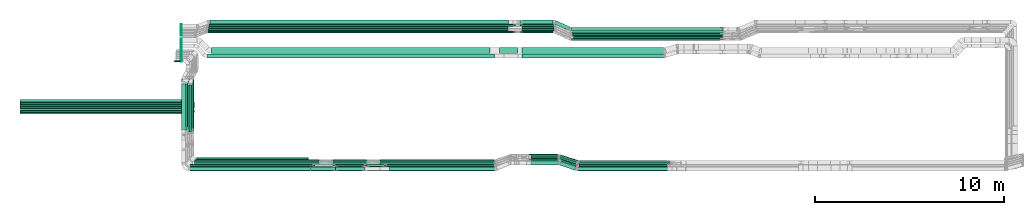
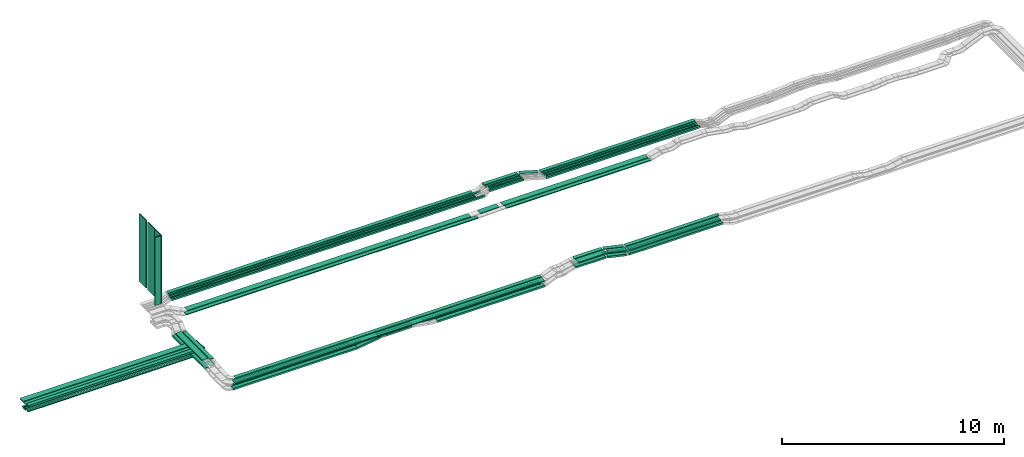
# One storey, part 1 of 28: 74 flow segments.
"""IFC2X3 building model written with IfcOpenShell, lengths in millimetres."""

from ifc_helpers import new_model, entity, si_unit, converted_unit, derived_unit, direction, frame, origin, origin_2d_with_axis, place, context, subcontext, project, spatial, rectangle, extrude, type_object, element, save


model = new_model("IFC2X3")

# Units and contexts
model_context = context("Model", 3, precision=0.01, world=origin(), true_north=direction((6.12303176911189e-17, 1.0)))
body_context = subcontext(model_context, "Body", "Model", "MODEL_VIEW")
ifc_project = project(units=[si_unit("LENGTHUNIT", "METRE", prefix="MILLI"), si_unit("AREAUNIT", "SQUARE_METRE"), si_unit("VOLUMEUNIT", "CUBIC_METRE"), converted_unit("PLANEANGLEUNIT", "DEGREE", entity("IfcRatioMeasure", 0.0174532925199433), si_unit("PLANEANGLEUNIT", "RADIAN"), dimensions=[0, 0, 0, 0, 0, 0, 0]), si_unit("MASSUNIT", "GRAM", prefix="KILO"), derived_unit("MASSDENSITYUNIT", [(si_unit("MASSUNIT", "GRAM", prefix="KILO"), 1), (si_unit("LENGTHUNIT", "METRE"), -3)]), derived_unit("MOMENTOFINERTIAUNIT", [(si_unit("LENGTHUNIT", "METRE"), 4)]), si_unit("TIMEUNIT", "SECOND"), si_unit("FREQUENCYUNIT", "HERTZ"), si_unit("THERMODYNAMICTEMPERATUREUNIT", "DEGREE_CELSIUS"), derived_unit("THERMALTRANSMITTANCEUNIT", [(si_unit("MASSUNIT", "GRAM", prefix="KILO"), 1), (si_unit("THERMODYNAMICTEMPERATUREUNIT", "KELVIN"), -1), (si_unit("TIMEUNIT", "SECOND"), -3)]), derived_unit("VOLUMETRICFLOWRATEUNIT", [(si_unit("LENGTHUNIT", "METRE"), 3), (si_unit("TIMEUNIT", "SECOND"), -1)]), derived_unit("MASSFLOWRATEUNIT", [(si_unit("MASSUNIT", "GRAM", prefix="KILO"), 1), (si_unit("TIMEUNIT", "SECOND"), -1)]), derived_unit("ROTATIONALFREQUENCYUNIT", [(si_unit("TIMEUNIT", "SECOND"), -1)]), si_unit("ELECTRICCURRENTUNIT", "AMPERE"), si_unit("ELECTRICVOLTAGEUNIT", "VOLT"), si_unit("POWERUNIT", "WATT"), si_unit("FORCEUNIT", "NEWTON", prefix="KILO"), si_unit("ILLUMINANCEUNIT", "LUX"), si_unit("LUMINOUSFLUXUNIT", "LUMEN"), si_unit("LUMINOUSINTENSITYUNIT", "CANDELA"), derived_unit("USERDEFINED", [(si_unit("MASSUNIT", "GRAM", prefix="KILO"), -1), (si_unit("LENGTHUNIT", "METRE"), -2), (si_unit("TIMEUNIT", "SECOND"), 3), (si_unit("LUMINOUSFLUXUNIT", "LUMEN"), 1)]), derived_unit("LINEARVELOCITYUNIT", [(si_unit("LENGTHUNIT", "METRE"), 1), (si_unit("TIMEUNIT", "SECOND"), -1)]), si_unit("PRESSUREUNIT", "PASCAL"), derived_unit("USERDEFINED", [(si_unit("LENGTHUNIT", "METRE"), -2), (si_unit("MASSUNIT", "GRAM", prefix="KILO"), 1), (si_unit("TIMEUNIT", "SECOND"), -2)]), derived_unit("LINEARFORCEUNIT", [(si_unit("MASSUNIT", "GRAM", prefix="KILO"), 1), (si_unit("LENGTHUNIT", "METRE"), 1), (si_unit("TIMEUNIT", "SECOND"), -2), (si_unit("LENGTHUNIT", "METRE"), -1)]), derived_unit("PLANARFORCEUNIT", [(si_unit("MASSUNIT", "GRAM", prefix="KILO"), 1), (si_unit("LENGTHUNIT", "METRE"), 1), (si_unit("TIMEUNIT", "SECOND"), -2), (si_unit("LENGTHUNIT", "METRE"), -2)])], contexts=[model_context])

# Site, building, storey
site_placement = place(None, origin())
site = spatial("IfcSite", under=ifc_project, at=site_placement, CompositionType="ELEMENT")
building_placement = place(site_placement, origin())
building = spatial("IfcBuilding", under=site, at=building_placement, CompositionType="ELEMENT")
storey_placement = place(building_placement, frame((0.0, 0.0, 15900.0)))
storey = spatial("IfcBuildingStorey", under=building, at=storey_placement, CompositionType="ELEMENT", Elevation=15900.0)

# Flow segments
cable_carrier_segment_type_1 = type_object("IfcCableCarrierSegmentType", PredefinedType="CABLETRAYSEGMENT")
flow_segment_1_placement = place(storey_placement, frame((17073.5, 10315.08, 2607.26)))
element("IfcFlowSegment", 1, at=flow_segment_1_placement, inside=storey, type_object=cable_carrier_segment_type_1, context=body_context, shape_type="SweptSolid", body=[
    extrude(rectangle(XDim=2780.65043288834, YDim=99.9999999999989, at=origin_2d_with_axis()), frame((50.0, 1390.33, 0.0), z_axis=(0.0, 0.0, 1.0), x_axis=(0.0, -1.0, 0.0)), (0.0, 0.0, 1.0), 99.9999999999989),
])
flow_segment_2_placement = place(storey_placement, frame((16853.5, 10214.44, 2607.26)))
element("IfcFlowSegment", 2, at=flow_segment_2_placement, inside=storey, type_object=cable_carrier_segment_type_1, context=body_context, shape_type="SweptSolid", body=[
    extrude(rectangle(XDim=2881.28895515389, YDim=99.9999999999989, at=origin_2d_with_axis()), frame((50.0, 1440.64, 0.0), z_axis=(0.0, 0.0, 1.0), x_axis=(0.0, -1.0, 0.0)), (0.0, 0.0, 1.0), 49.9999999999995),
])
flow_segment_3_placement = place(storey_placement, frame((8000.0, 11314.49, 2532.26)))
element("IfcFlowSegment", 3, at=flow_segment_3_placement, inside=storey, type_object=cable_carrier_segment_type_1, context=body_context, shape_type="SweptSolid", body=[
    extrude(rectangle(XDim=9200.0, YDim=99.9999999999989, at=origin_2d_with_axis()), frame((4600.0, 50.0, 0.0)), (0.0, 0.0, 1.0), 50.0000000000016),
])
flow_segment_4_placement = place(storey_placement, frame((7981.52, 11524.49, 2507.26)))
element("IfcFlowSegment", 4, at=flow_segment_4_placement, inside=storey, type_object=cable_carrier_segment_type_1, context=body_context, shape_type="SweptSolid", body=[
    extrude(rectangle(XDim=9218.48463988693, YDim=99.9999999999989, at=origin_2d_with_axis()), frame((4609.24, 50.0, 0.0)), (0.0, 0.0, 1.0), 99.9999999999989),
])
flow_segment_5_placement = place(storey_placement, frame((7981.52, 11638.05, 2507.26)))
element("IfcFlowSegment", 5, at=flow_segment_5_placement, inside=storey, type_object=cable_carrier_segment_type_1, context=body_context, shape_type="SweptSolid", body=[
    extrude(rectangle(XDim=9218.48463988694, YDim=99.9999999999989, at=origin_2d_with_axis()), frame((4609.24, 50.0, 0.0)), (0.0, 0.0, 1.0), 50.0000000000016),
])
flow_segment_6_placement = place(storey_placement, frame((8000.0, 11748.05, 2507.26)))
element("IfcFlowSegment", 6, at=flow_segment_6_placement, inside=storey, type_object=cable_carrier_segment_type_1, context=body_context, shape_type="SweptSolid", body=[
    extrude(rectangle(XDim=9200.0, YDim=99.9999999999989, at=origin_2d_with_axis()), frame((4600.0, 50.0, 0.0)), (0.0, 0.0, 1.0), 50.0000000000016),
])
flow_segment_7_placement = place(storey_placement, frame((7970.7, 11214.35, 2865.0)))
element("IfcFlowSegment", 7, at=flow_segment_7_placement, inside=storey, type_object=cable_carrier_segment_type_1, context=body_context, shape_type="SweptSolid", body=[
    extrude(rectangle(XDim=9180.0, YDim=200.000000000002, at=origin_2d_with_axis()), frame((4590.0, 100.0, 0.0)), (0.0, 0.0, 1.0), 100.000000000001),
])
flow_segment_8_placement = place(storey_placement, frame((7970.7, 11450.62, 2865.0)))
element("IfcFlowSegment", 8, at=flow_segment_8_placement, inside=storey, type_object=cable_carrier_segment_type_1, context=body_context, shape_type="SweptSolid", body=[
    extrude(rectangle(XDim=9180.0, YDim=199.999999999998, at=origin_2d_with_axis()), frame((4590.0, 100.0, 0.0)), (0.0, 0.0, 1.0), 50.0000000000016),
])
flow_segment_9_placement = place(storey_placement, frame((7970.7, 11685.62, 2865.0)))
element("IfcFlowSegment", 9, at=flow_segment_9_placement, inside=storey, type_object=cable_carrier_segment_type_1, context=body_context, shape_type="SweptSolid", body=[
    extrude(rectangle(XDim=9180.0, YDim=300.000000000001, at=origin_2d_with_axis()), frame((4590.0, 150.0, 0.0)), (0.0, 0.0, 1.0), 50.0000000000016),
])
flow_segment_10_placement = place(storey_placement, frame((24529.62, 8454.97, 2685.0)))
element("IfcFlowSegment", 10, at=flow_segment_10_placement, inside=storey, type_object=cable_carrier_segment_type_1, context=body_context, shape_type="SweptSolid", body=[
    extrude(rectangle(XDim=1786.26303875484, YDim=99.9999999999989, at=origin_2d_with_axis()), frame((893.13, 50.0, 0.0), z_axis=(0.0, 0.0, 1.0), x_axis=(-1.0, 0.0, 0.0)), (0.0, 0.0, 1.0), 99.9999999999989),
])
flow_segment_11_placement = place(storey_placement, frame((24526.24, 8695.5, 2685.0)))
element("IfcFlowSegment", 11, at=flow_segment_11_placement, inside=storey, type_object=cable_carrier_segment_type_1, context=body_context, shape_type="SweptSolid", body=[
    extrude(rectangle(XDim=1802.89625010228, YDim=99.9999999999989, at=origin_2d_with_axis()), frame((901.45, 50.0, 0.0), z_axis=(0.0, 0.0, 1.0), x_axis=(-1.0, 0.0, 0.0)), (0.0, 0.0, 1.0), 50.0000000000016),
])
flow_segment_12_placement = place(storey_placement, frame((27287.24, 8454.97, 2500.0)))
element("IfcFlowSegment", 12, at=flow_segment_12_placement, inside=storey, type_object=cable_carrier_segment_type_1, context=body_context, shape_type="SweptSolid", body=[
    extrude(rectangle(XDim=5758.36690365423, YDim=99.9999999999989, at=origin_2d_with_axis()), frame((2879.18, 50.0, 0.0)), (0.0, 0.0, 1.0), 99.9999999999968),
])
flow_segment_13_placement = place(storey_placement, frame((27017.8, 8695.5, 2500.0)))
element("IfcFlowSegment", 13, at=flow_segment_13_placement, inside=storey, type_object=cable_carrier_segment_type_1, context=body_context, shape_type="SweptSolid", body=[
    extrude(rectangle(XDim=6063.03813263292, YDim=99.9999999999989, at=origin_2d_with_axis()), frame((3031.52, 50.0, 0.0)), (0.0, 0.0, 1.0), 50.0000000000016),
])
flow_segment_14_placement = place(storey_placement, frame((26318.63, 8454.97, 2502.07)))
element("IfcFlowSegment", 14, at=flow_segment_14_placement, inside=storey, type_object=cable_carrier_segment_type_1, context=body_context, shape_type="SweptSolid", body=[
    extrude(rectangle(XDim=99.9999999999993, YDim=99.9999999999989, at=origin_2d_with_axis()), frame((9.47, 50.0, 231.76), z_axis=(0.981897917883988, 0.0, -0.189410873117385), x_axis=(0.189410873117385, 0.0, 0.981897917883988)), (0.0, 0.0, 1.0), 964.391063611438),
])
flow_segment_15_placement = place(storey_placement, frame((37472.04, 8224.97, 2710.0)))
element("IfcFlowSegment", 15, at=flow_segment_15_placement, inside=storey, type_object=cable_carrier_segment_type_1, context=body_context, shape_type="SweptSolid", body=[
    extrude(rectangle(XDim=4888.31327705013, YDim=200.0, at=origin_2d_with_axis()), frame((2444.16, 100.0, 0.0), z_axis=(0.0, 0.0, 1.0), x_axis=(-1.0, 0.0, 0.0)), (0.0, 0.0, 1.0), 99.9999999999968),
])
flow_segment_16_placement = place(storey_placement, frame((37506.0, 8550.15, 2960.0)))
element("IfcFlowSegment", 16, at=flow_segment_16_placement, inside=storey, type_object=cable_carrier_segment_type_1, context=body_context, shape_type="SweptSolid", body=[
    extrude(rectangle(XDim=4857.14151539678, YDim=200.0, at=origin_2d_with_axis()), frame((2428.57, 100.0, 0.0), z_axis=(0.0, 0.0, 1.0), x_axis=(-1.0, 0.0, 0.0)), (0.0, 0.0, 1.0), 50.0000000000016),
])
flow_segment_17_placement = place(storey_placement, frame((37499.8, 8215.15, 2960.0)))
element("IfcFlowSegment", 17, at=flow_segment_17_placement, inside=storey, type_object=cable_carrier_segment_type_1, context=body_context, shape_type="SweptSolid", body=[
    extrude(rectangle(XDim=4763.81493661313, YDim=299.999999999999, at=origin_2d_with_axis()), frame((2381.91, 150.0, 0.0), z_axis=(0.0, 0.0, 1.0), x_axis=(-1.0, 0.0, 0.0)), (0.0, 0.0, 1.0), 50.0000000000016),
])
flow_segment_18_placement = place(storey_placement, frame((37556.09, 8434.97, 2710.0)))
element("IfcFlowSegment", 18, at=flow_segment_18_placement, inside=storey, type_object=cable_carrier_segment_type_1, context=body_context, shape_type="SweptSolid", body=[
    extrude(rectangle(XDim=4808.31327705014, YDim=99.9999999999989, at=origin_2d_with_axis()), frame((2404.16, 50.0, 0.0), z_axis=(0.0, 0.0, 1.0), x_axis=(-1.0, 0.0, 0.0)), (0.0, 0.0, 1.0), 99.9999999999989),
])
flow_segment_19_placement = place(storey_placement, frame((37576.5, 8654.97, 2710.6)))
element("IfcFlowSegment", 19, at=flow_segment_19_placement, inside=storey, type_object=cable_carrier_segment_type_1, context=body_context, shape_type="SweptSolid", body=[
    extrude(rectangle(XDim=4789.76682509452, YDim=100.000000000001, at=origin_2d_with_axis()), frame((2394.88, 50.0, 0.0), z_axis=(0.0, 0.0, 1.0), x_axis=(-1.0, 0.0, 0.0)), (0.0, 0.0, 1.0), 50.0000000000016),
])
flow_segment_20_placement = place(storey_placement, frame((34904.88, 8985.15, 2710.6)))
element("IfcFlowSegment", 20, at=flow_segment_20_placement, inside=storey, type_object=cable_carrier_segment_type_1, context=body_context, shape_type="SweptSolid", body=[
    extrude(rectangle(XDim=1535.81415113666, YDim=100.000000000001, at=origin_2d_with_axis()), frame((767.91, 50.0, 0.0)), (0.0, 0.0, 1.0), 50.0000000000016),
])
flow_segment_21_placement = place(storey_placement, frame((36519.05, 8243.65, 2710.0)))
element("IfcFlowSegment", 21, at=flow_segment_21_placement, inside=storey, type_object=cable_carrier_segment_type_1, context=body_context, shape_type="SweptSolid", body=[
    extrude(rectangle(XDim=885.621574951497, YDim=200.000000000006, at=origin_2d_with_axis()), frame((451.54, 236.31, 0.0), z_axis=(0.0, 0.0, 1.0), x_axis=(-0.947523036731155, 0.319687495632485, 0.0)), (0.0, 0.0, 1.0), 99.9999999999989),
])
flow_segment_22_placement = place(storey_placement, frame((36528.68, 8567.93, 2960.0)))
element("IfcFlowSegment", 22, at=flow_segment_22_placement, inside=storey, type_object=cable_carrier_segment_type_1, context=body_context, shape_type="SweptSolid", body=[
    extrude(rectangle(XDim=911.680400926984, YDim=200.000000000001, at=origin_2d_with_axis()), frame((464.29, 237.22, 0.0), z_axis=(0.0, 0.0, 1.0), x_axis=(-0.950090398751314, 0.311974733272694, 0.0)), (0.0, 0.0, 1.0), 50.0000000000016),
])
flow_segment_23_placement = place(storey_placement, frame((36540.53, 8239.6, 2960.0)))
element("IfcFlowSegment", 23, at=flow_segment_23_placement, inside=storey, type_object=cable_carrier_segment_type_1, context=body_context, shape_type="SweptSolid", body=[
    extrude(rectangle(XDim=857.94012161665, YDim=299.999999999997, at=origin_2d_with_axis()), frame((454.43, 280.55, 0.0), z_axis=(0.0, 0.0, 1.0), x_axis=(-0.946373728466921, 0.323073932819747, 0.0)), (0.0, 0.0, 1.0), 50.0000000000016),
])
flow_segment_24_placement = place(storey_placement, frame((16963.5, 10214.44, 2607.26)))
element("IfcFlowSegment", 24, at=flow_segment_24_placement, inside=storey, type_object=cable_carrier_segment_type_1, context=body_context, shape_type="SweptSolid", body=[
    extrude(rectangle(XDim=2881.28895515389, YDim=99.9999999999989, at=origin_2d_with_axis()), frame((50.0, 1440.64, 0.0), z_axis=(0.0, 0.0, 1.0), x_axis=(0.0, -1.0, 0.0)), (0.0, 0.0, 1.0), 49.9999999999995),
])
flow_segment_25_placement = place(storey_placement, frame((24526.24, 8575.5, 2685.0)))
element("IfcFlowSegment", 25, at=flow_segment_25_placement, inside=storey, type_object=cable_carrier_segment_type_1, context=body_context, shape_type="SweptSolid", body=[
    extrude(rectangle(XDim=1802.89625010228, YDim=100.000000000001, at=origin_2d_with_axis()), frame((901.45, 50.0, 0.0), z_axis=(0.0, 0.0, 1.0), x_axis=(-1.0, 0.0, 0.0)), (0.0, 0.0, 1.0), 50.0000000000016),
])
flow_segment_26_placement = place(storey_placement, frame((27017.8, 8575.5, 2500.0)))
element("IfcFlowSegment", 26, at=flow_segment_26_placement, inside=storey, type_object=cable_carrier_segment_type_1, context=body_context, shape_type="SweptSolid", body=[
    extrude(rectangle(XDim=6046.06785474926, YDim=100.000000000001, at=origin_2d_with_axis()), frame((3023.03, 50.0, 0.0)), (0.0, 0.0, 1.0), 50.0000000000016),
])
flow_segment_27_placement = place(storey_placement, frame((37560.24, 8544.97, 2710.64)))
element("IfcFlowSegment", 27, at=flow_segment_27_placement, inside=storey, type_object=cable_carrier_segment_type_1, context=body_context, shape_type="SweptSolid", body=[
    extrude(rectangle(XDim=4809.76682509451, YDim=100.000000000001, at=origin_2d_with_axis()), frame((2404.88, 50.0, 0.0), z_axis=(0.0, 0.0, 1.0), x_axis=(-1.0, 0.0, 0.0)), (0.0, 0.0, 1.0), 50.0000000000016),
])
flow_segment_28_placement = place(storey_placement, frame((24678.48, 8224.97, 2685.0)))
element("IfcFlowSegment", 28, at=flow_segment_28_placement, inside=storey, type_object=cable_carrier_segment_type_1, context=body_context, shape_type="SweptSolid", body=[
    extrude(rectangle(XDim=1528.31463009343, YDim=200.0, at=origin_2d_with_axis()), frame((764.16, 100.0, 0.0), z_axis=(0.0, 0.0, 1.0), x_axis=(-1.0, 0.0, 0.0)), (0.0, 0.0, 1.0), 99.9999999999989),
])
flow_segment_29_placement = place(storey_placement, frame((27523.82, 8224.97, 2500.0)))
element("IfcFlowSegment", 29, at=flow_segment_29_placement, inside=storey, type_object=cable_carrier_segment_type_1, context=body_context, shape_type="SweptSolid", body=[
    extrude(rectangle(XDim=5594.92379897543, YDim=200.0, at=origin_2d_with_axis()), frame((2797.46, 100.0, 0.0), z_axis=(0.0, 0.0, 1.0), x_axis=(-1.0, 0.0, 0.0)), (0.0, 0.0, 1.0), 99.9999999999968),
])
flow_segment_30_placement = place(storey_placement, frame((23349.89, 8224.97, 2501.44)))
element("IfcFlowSegment", 30, at=flow_segment_30_placement, inside=storey, type_object=cable_carrier_segment_type_1, context=body_context, shape_type="SweptSolid", body=[
    extrude(rectangle(XDim=100.000000000002, YDim=200.0, at=origin_2d_with_axis()), frame((6.92, 100.0, 49.52), z_axis=(0.990375964698783, 0.0, 0.138403210031255), x_axis=(-0.138403210031255, 0.0, 0.990375964698783)), (0.0, 0.0, 1.0), 1324.96562263443),
])
flow_segment_31_placement = place(storey_placement, frame((36498.85, 8446.3, 2710.0)))
element("IfcFlowSegment", 31, at=flow_segment_31_placement, inside=storey, type_object=cable_carrier_segment_type_1, context=body_context, shape_type="SweptSolid", body=[
    extrude(rectangle(XDim=1027.17142103154, YDim=100.000000000001, at=origin_2d_with_axis()), frame((505.59, 198.75, 0.0), z_axis=(0.0, 0.0, 1.0), x_axis=(-0.955824550369197, 0.293937797691149, 0.0)), (0.0, 0.0, 1.0), 99.9999999999989),
])
flow_segment_32_placement = place(storey_placement, frame((36486.75, 8556.3, 2710.64)))
element("IfcFlowSegment", 32, at=flow_segment_32_placement, inside=storey, type_object=cable_carrier_segment_type_1, context=body_context, shape_type="SweptSolid", body=[
    extrude(rectangle(XDim=1044.18182268543, YDim=99.9999999999993, at=origin_2d_with_axis()), frame((513.72, 201.25, 0.0), z_axis=(0.0, 0.0, 1.0), x_axis=(0.955824550369191, -0.293937797691166, 0.0)), (0.0, 0.0, 1.0), 50.0000000000016),
])
flow_segment_33_placement = place(storey_placement, frame((36486.75, 8666.3, 2710.6)))
element("IfcFlowSegment", 33, at=flow_segment_33_placement, inside=storey, type_object=cable_carrier_segment_type_1, context=body_context, shape_type="SweptSolid", body=[
    extrude(rectangle(XDim=1061.19222433936, YDim=100.000000000001, at=origin_2d_with_axis()), frame((521.85, 203.75, 0.0), z_axis=(0.0, 0.0, 1.0), x_axis=(-0.955824550369194, 0.293937797691157, 0.0)), (0.0, 0.0, 1.0), 50.0000000000016),
])
flow_segment_34_placement = place(storey_placement, frame((35019.58, 8525.15, 2960.0)))
element("IfcFlowSegment", 34, at=flow_segment_34_placement, inside=storey, type_object=cable_carrier_segment_type_1, context=body_context, shape_type="SweptSolid", body=[
    extrude(rectangle(XDim=1470.54834923566, YDim=299.999999999999, at=origin_2d_with_axis()), frame((735.27, 150.0, 0.0), z_axis=(0.0, 0.0, 1.0), x_axis=(-1.0, 0.0, 0.0)), (0.0, 0.0, 1.0), 50.0000000000016),
])
flow_segment_35_placement = place(storey_placement, frame((35014.7, 8860.15, 2960.0)))
element("IfcFlowSegment", 35, at=flow_segment_35_placement, inside=storey, type_object=cable_carrier_segment_type_1, context=body_context, shape_type="SweptSolid", body=[
    extrude(rectangle(XDim=1465.22943402716, YDim=200.0, at=origin_2d_with_axis()), frame((732.61, 100.0, 0.0), z_axis=(0.0, 0.0, 1.0), x_axis=(-1.0, 0.0, 0.0)), (0.0, 0.0, 1.0), 50.0000000000016),
])
flow_segment_36_placement = place(storey_placement, frame((34902.38, 8870.15, 2710.64)))
element("IfcFlowSegment", 36, at=flow_segment_36_placement, inside=storey, type_object=cable_carrier_segment_type_1, context=body_context, shape_type="SweptSolid", body=[
    extrude(rectangle(XDim=1538.31890673293, YDim=99.9999999999989, at=origin_2d_with_axis()), frame((769.16, 50.0, 0.0), z_axis=(0.0, 0.0, 1.0), x_axis=(-1.0, 0.0, 0.0)), (0.0, 0.0, 1.0), 50.0000000000016),
])
flow_segment_37_placement = place(storey_placement, frame((34899.57, 8755.15, 2710.0)))
element("IfcFlowSegment", 37, at=flow_segment_37_placement, inside=storey, type_object=cable_carrier_segment_type_1, context=body_context, shape_type="SweptSolid", body=[
    extrude(rectangle(XDim=1553.23442459964, YDim=99.9999999999989, at=origin_2d_with_axis()), frame((776.62, 50.0, 0.0), z_axis=(0.0, 0.0, 1.0), x_axis=(-1.0, 0.0, 0.0)), (0.0, 0.0, 1.0), 99.9999999999989),
])
flow_segment_38_placement = place(storey_placement, frame((34897.29, 8534.97, 2710.0)))
element("IfcFlowSegment", 38, at=flow_segment_38_placement, inside=storey, type_object=cable_carrier_segment_type_1, context=body_context, shape_type="SweptSolid", body=[
    extrude(rectangle(XDim=1571.85756666243, YDim=200.0, at=origin_2d_with_axis()), frame((785.93, 100.0, 0.0), z_axis=(0.0, 0.0, 1.0), x_axis=(-1.0, 0.0, 0.0)), (0.0, 0.0, 1.0), 99.9999999999989),
])
flow_segment_39_placement = place(storey_placement, frame((34443.08, 15514.99, 2834.96)))
element("IfcFlowSegment", 39, at=flow_segment_39_placement, inside=storey, type_object=cable_carrier_segment_type_1, context=body_context, shape_type="SweptSolid", body=[
    extrude(rectangle(XDim=1770.27078387069, YDim=99.9999999999989, at=origin_2d_with_axis()), frame((885.14, 50.0, 0.0), z_axis=(0.0, 0.0, 1.0), x_axis=(-1.0, 0.0, 0.0)), (0.0, 0.0, 1.0), 99.9999999999989),
])
flow_segment_40_placement = place(storey_placement, frame((34544.44, 15629.46, 2838.0)))
element("IfcFlowSegment", 40, at=flow_segment_40_placement, inside=storey, type_object=cable_carrier_segment_type_1, context=body_context, shape_type="SweptSolid", body=[
    extrude(rectangle(XDim=1705.90442705846, YDim=99.9999999999989, at=origin_2d_with_axis()), frame((852.95, 50.0, 0.0)), (0.0, 0.0, 1.0), 50.0000000000038),
])
flow_segment_41_placement = place(storey_placement, frame((34544.44, 15749.46, 2838.0)))
element("IfcFlowSegment", 41, at=flow_segment_41_placement, inside=storey, type_object=cable_carrier_segment_type_1, context=body_context, shape_type="SweptSolid", body=[
    extrude(rectangle(XDim=1705.9044270585, YDim=99.9999999999989, at=origin_2d_with_axis()), frame((852.95, 50.0, 0.0)), (0.0, 0.0, 1.0), 50.0000000000038),
])
flow_segment_42_placement = place(storey_placement, frame((34446.68, 15869.99, 2835.0)))
element("IfcFlowSegment", 42, at=flow_segment_42_placement, inside=storey, type_object=cable_carrier_segment_type_1, context=body_context, shape_type="SweptSolid", body=[
    extrude(rectangle(XDim=1788.24023623879, YDim=99.9999999999989, at=origin_2d_with_axis()), frame((894.12, 50.0, 0.0), z_axis=(0.0, 0.0, 1.0), x_axis=(-1.0, 0.0, 0.0)), (0.0, 0.0, 1.0), 99.9999999999989),
])
flow_segment_43_placement = place(storey_placement, frame((34447.93, 15999.99, 2835.0)))
element("IfcFlowSegment", 43, at=flow_segment_43_placement, inside=storey, type_object=cable_carrier_segment_type_1, context=body_context, shape_type="SweptSolid", body=[
    extrude(rectangle(XDim=1748.79198590572, YDim=199.999999999998, at=origin_2d_with_axis()), frame((874.4, 100.0, 0.0), z_axis=(0.0, 0.0, 1.0), x_axis=(-1.0, 0.0, 0.0)), (0.0, 0.0, 1.0), 99.9999999999989),
])
flow_segment_44_placement = place(storey_placement, frame((34536.97, 14435.03, 2675.0)))
element("IfcFlowSegment", 44, at=flow_segment_44_placement, inside=storey, type_object=cable_carrier_segment_type_1, context=body_context, shape_type="SweptSolid", body=[
    extrude(rectangle(XDim=7521.02349391717, YDim=300.000000000001, at=origin_2d_with_axis()), frame((3760.51, 150.0, 0.0), z_axis=(0.0, 0.0, 1.0), x_axis=(-1.0, 0.0, 0.0)), (0.0, 0.0, 1.0), 50.0000000000016),
])
flow_segment_45_placement = place(storey_placement, frame((34556.92, 14200.03, 2675.0)))
element("IfcFlowSegment", 45, at=flow_segment_45_placement, inside=storey, type_object=cable_carrier_segment_type_1, context=body_context, shape_type="SweptSolid", body=[
    extrude(rectangle(XDim=7508.26665724989, YDim=199.999999999998, at=origin_2d_with_axis()), frame((3754.13, 100.0, 0.0), z_axis=(0.0, 0.0, 1.0), x_axis=(-1.0, 0.0, 0.0)), (0.0, 0.0, 1.0), 50.0000000000016),
])
flow_segment_46_placement = place(storey_placement, frame((37169.47, 15609.99, 2835.0)))
element("IfcFlowSegment", 46, at=flow_segment_46_placement, inside=storey, type_object=cable_carrier_segment_type_1, context=body_context, shape_type="SweptSolid", body=[
    extrude(rectangle(XDim=8013.73124229196, YDim=200.000000000002, at=origin_2d_with_axis()), frame((4006.87, 100.0, 0.0)), (0.0, 0.0, 1.0), 99.9999999999989),
])
flow_segment_47_placement = place(storey_placement, frame((37186.13, 15479.99, 2835.0)))
element("IfcFlowSegment", 47, at=flow_segment_47_placement, inside=storey, type_object=cable_carrier_segment_type_1, context=body_context, shape_type="SweptSolid", body=[
    extrude(rectangle(XDim=7996.88069095725, YDim=99.9999999999989, at=origin_2d_with_axis()), frame((3998.44, 50.0, 0.0)), (0.0, 0.0, 1.0), 99.9999999999989),
])
flow_segment_48_placement = place(storey_placement, frame((37201.55, 15359.46, 2838.0)))
element("IfcFlowSegment", 48, at=flow_segment_48_placement, inside=storey, type_object=cable_carrier_segment_type_1, context=body_context, shape_type="SweptSolid", body=[
    extrude(rectangle(XDim=7980.27118863344, YDim=99.9999999999989, at=origin_2d_with_axis()), frame((3990.14, 50.0, 0.0)), (0.0, 0.0, 1.0), 50.0000000000016),
])
flow_segment_49_placement = place(storey_placement, frame((37267.02, 15239.46, 2838.0)))
element("IfcFlowSegment", 49, at=flow_segment_49_placement, inside=storey, type_object=cable_carrier_segment_type_1, context=body_context, shape_type="SweptSolid", body=[
    extrude(rectangle(XDim=7914.79796234961, YDim=99.9999999999989, at=origin_2d_with_axis()), frame((3957.4, 50.0, 0.0)), (0.0, 0.0, 1.0), 50.0000000000016),
])
flow_segment_50_placement = place(storey_placement, frame((37164.55, 15124.99, 2834.96)))
element("IfcFlowSegment", 50, at=flow_segment_50_placement, inside=storey, type_object=cable_carrier_segment_type_1, context=body_context, shape_type="SweptSolid", body=[
    extrude(rectangle(XDim=8018.77837251078, YDim=99.9999999999989, at=origin_2d_with_axis()), frame((4009.39, 50.0, 0.0), z_axis=(0.0, 0.0, 1.0), x_axis=(-1.0, 0.0, 0.0)), (0.0, 0.0, 1.0), 99.9999999999989),
])
flow_segment_51_placement = place(storey_placement, frame((33350.19, 14435.03, 2654.73)))
element("IfcFlowSegment", 51, at=flow_segment_51_placement, inside=storey, type_object=cable_carrier_segment_type_1, context=body_context, shape_type="SweptSolid", body=[
    extrude(rectangle(XDim=50.0000000000006, YDim=300.000000000001, at=origin_2d_with_axis()), frame((0.47, 150.0, 25.0), z_axis=(0.999821042344905, 0.0, 0.0189178033700684), x_axis=(-0.0189178033700684, 0.0, 0.999821042344905)), (0.0, 0.0, 1.0), 956.946818410146),
])
flow_segment_52_placement = place(storey_placement, frame((36260.4, 15641.46, 2835.0)))
element("IfcFlowSegment", 52, at=flow_segment_52_placement, inside=storey, type_object=cable_carrier_segment_type_1, context=body_context, shape_type="SweptSolid", body=[
    extrude(rectangle(XDim=837.315637086008, YDim=200.0, at=origin_2d_with_axis()), frame((422.69, 263.53, 0.0), z_axis=(0.0, 0.0, 1.0), x_axis=(0.911271304124217, -0.411806520443459, 0.0)), (0.0, 0.0, 1.0), 99.9999999999989),
])
flow_segment_53_placement = place(storey_placement, frame((17896.51, 14200.03, 2650.0)))
element("IfcFlowSegment", 53, at=flow_segment_53_placement, inside=storey, type_object=cable_carrier_segment_type_1, context=body_context, shape_type="SweptSolid", body=[
    extrude(rectangle(XDim=15194.6626405814, YDim=200.000000000002, at=origin_2d_with_axis()), frame((7597.33, 100.0, 0.0), z_axis=(0.0, 0.0, 1.0), x_axis=(-1.0, 0.0, 0.0)), (0.0, 0.0, 1.0), 50.0000000000016),
])
flow_segment_54_placement = place(storey_placement, frame((18018.62, 15999.99, 2635.0)))
element("IfcFlowSegment", 54, at=flow_segment_54_placement, inside=storey, type_object=cable_carrier_segment_type_1, context=body_context, shape_type="SweptSolid", body=[
    extrude(rectangle(XDim=15812.8789784224, YDim=199.999999999998, at=origin_2d_with_axis()), frame((7906.44, 100.0, 0.0), z_axis=(0.0, 0.0, 1.0), x_axis=(-1.0, 0.0, 0.0)), (0.0, 0.0, 1.0), 99.9999999999989),
])
flow_segment_55_placement = place(storey_placement, frame((17969.59, 15869.99, 2635.0)))
element("IfcFlowSegment", 55, at=flow_segment_55_placement, inside=storey, type_object=cable_carrier_segment_type_1, context=body_context, shape_type="SweptSolid", body=[
    extrude(rectangle(XDim=16230.3622457112, YDim=99.9999999999989, at=origin_2d_with_axis()), frame((8115.18, 50.0, 0.0), z_axis=(0.0, 0.0, 1.0), x_axis=(-1.0, 0.0, 0.0)), (0.0, 0.0, 1.0), 99.9999999999989),
])
flow_segment_56_placement = place(storey_placement, frame((17929.59, 15749.46, 2638.31)))
element("IfcFlowSegment", 56, at=flow_segment_56_placement, inside=storey, type_object=cable_carrier_segment_type_1, context=body_context, shape_type="SweptSolid", body=[
    extrude(rectangle(XDim=15901.9167428009, YDim=99.9999999999989, at=origin_2d_with_axis()), frame((7950.96, 50.0, 0.0), z_axis=(0.0, 0.0, 1.0), x_axis=(-1.0, 0.0, 0.0)), (0.0, 0.0, 1.0), 50.0000000000016),
])
flow_segment_57_placement = place(storey_placement, frame((17909.59, 15629.46, 2638.31)))
element("IfcFlowSegment", 57, at=flow_segment_57_placement, inside=storey, type_object=cable_carrier_segment_type_1, context=body_context, shape_type="SweptSolid", body=[
    extrude(rectangle(XDim=15921.9167428008, YDim=99.9999999999989, at=origin_2d_with_axis()), frame((7960.96, 50.0, 0.0), z_axis=(0.0, 0.0, 1.0), x_axis=(-1.0, 0.0, 0.0)), (0.0, 0.0, 1.0), 50.0000000000016),
])
flow_segment_58_placement = place(storey_placement, frame((17909.59, 15514.99, 2635.0)))
element("IfcFlowSegment", 58, at=flow_segment_58_placement, inside=storey, type_object=cable_carrier_segment_type_1, context=body_context, shape_type="SweptSolid", body=[
    extrude(rectangle(XDim=16286.8021542969, YDim=99.9999999999989, at=origin_2d_with_axis()), frame((8143.4, 50.0, 0.0), z_axis=(0.0, 0.0, 1.0), x_axis=(-1.0, 0.0, 0.0)), (0.0, 0.0, 1.0), 99.9999999999989),
])
flow_segment_59_placement = place(storey_placement, frame((18117.26, 14435.03, 2650.0)))
element("IfcFlowSegment", 59, at=flow_segment_59_placement, inside=storey, type_object=cable_carrier_segment_type_1, context=body_context, shape_type="SweptSolid", body=[
    extrude(rectangle(XDim=14733.8824230187, YDim=300.000000000001, at=origin_2d_with_axis()), frame((7366.94, 150.0, 0.0), z_axis=(0.0, 0.0, 1.0), x_axis=(-1.0, 0.0, 0.0)), (0.0, 0.0, 1.0), 50.0000000000016),
])
flow_segment_60_placement = place(storey_placement, frame((16868.5, 10277.1, 2927.26)))
element("IfcFlowSegment", 60, at=flow_segment_60_placement, inside=storey, type_object=cable_carrier_segment_type_1, context=body_context, shape_type="SweptSolid", body=[
    extrude(rectangle(XDim=2486.8289313542, YDim=199.999999999998, at=origin_2d_with_axis()), frame((100.0, 1243.41, 0.0), z_axis=(0.0, 0.0, 1.0), x_axis=(0.0, -1.0, 0.0)), (0.0, 0.0, 1.0), 50.0000000000016),
])
flow_segment_61_placement = place(storey_placement, frame((16533.5, 10116.68, 2607.26)))
element("IfcFlowSegment", 61, at=flow_segment_61_placement, inside=storey, type_object=cable_carrier_segment_type_1, context=body_context, shape_type="SweptSolid", body=[
    extrude(rectangle(XDim=2965.77768760925, YDim=199.999999999998, at=origin_2d_with_axis()), frame((100.0, 1482.89, 0.0), z_axis=(0.0, 0.0, 1.0), x_axis=(0.0, -1.0, 0.0)), (0.0, 0.0, 1.0), 99.9999999999989),
])
flow_segment_62_placement = place(storey_placement, frame((16743.5, 10374.74, 2607.26)))
element("IfcFlowSegment", 62, at=flow_segment_62_placement, inside=storey, type_object=cable_carrier_segment_type_1, context=body_context, shape_type="SweptSolid", body=[
    extrude(rectangle(XDim=2720.99555991448, YDim=99.9999999999989, at=origin_2d_with_axis()), frame((50.0, 1360.5, 0.0), z_axis=(0.0, 0.0, 1.0), x_axis=(0.0, -1.0, 0.0)), (0.0, 0.0, 1.0), 99.9999999999989),
])
flow_segment_63_placement = place(storey_placement, frame((16533.5, 10387.59, 2927.26)))
element("IfcFlowSegment", 63, at=flow_segment_63_placement, inside=storey, type_object=cable_carrier_segment_type_1, context=body_context, shape_type="SweptSolid", body=[
    extrude(rectangle(XDim=2432.92202283433, YDim=300.000000000001, at=origin_2d_with_axis()), frame((150.0, 1216.46, 0.0), z_axis=(0.0, 0.0, 1.0), x_axis=(0.0, -1.0, 0.0)), (0.0, 0.0, 1.0), 50.0000000000016),
])
flow_segment_64_placement = place(storey_placement, frame((16884.5, 8224.97, 2500.0)))
element("IfcFlowSegment", 64, at=flow_segment_64_placement, inside=storey, type_object=cable_carrier_segment_type_1, context=body_context, shape_type="SweptSolid", body=[
    extrude(rectangle(XDim=6458.46641712016, YDim=200.0, at=origin_2d_with_axis()), frame((3229.23, 100.0, 0.0), z_axis=(0.0, 0.0, 1.0), x_axis=(-1.0, 0.0, 0.0)), (0.0, 0.0, 1.0), 100.000000000001),
])
flow_segment_65_placement = place(storey_placement, frame((16994.5, 8454.97, 2500.0)))
element("IfcFlowSegment", 65, at=flow_segment_65_placement, inside=storey, type_object=cable_carrier_segment_type_1, context=body_context, shape_type="SweptSolid", body=[
    extrude(rectangle(XDim=6590.24096142334, YDim=100.000000000001, at=origin_2d_with_axis()), frame((3295.12, 50.0, 0.0), z_axis=(0.0, 0.0, 1.0), x_axis=(-1.0, 0.0, 0.0)), (0.0, 0.0, 1.0), 99.9999999999989),
])
flow_segment_66_placement = place(storey_placement, frame((17104.5, 8575.5, 2500.0)))
element("IfcFlowSegment", 66, at=flow_segment_66_placement, inside=storey, type_object=cable_carrier_segment_type_1, context=body_context, shape_type="SweptSolid", body=[
    extrude(rectangle(XDim=6707.50276899426, YDim=100.000000000001, at=origin_2d_with_axis()), frame((3353.75, 50.0, 0.0)), (0.0, 0.0, 1.0), 50.0000000000016),
])
flow_segment_67_placement = place(storey_placement, frame((17214.5, 8695.5, 2500.0)))
element("IfcFlowSegment", 67, at=flow_segment_67_placement, inside=storey, type_object=cable_carrier_segment_type_1, context=body_context, shape_type="SweptSolid", body=[
    extrude(rectangle(XDim=6597.50276899426, YDim=100.000000000001, at=origin_2d_with_axis()), frame((3298.75, 50.0, 0.0)), (0.0, 0.0, 1.0), 50.0000000000016),
])
flow_segment_68_placement = place(storey_placement, frame((17324.5, 8809.97, 2500.0)))
element("IfcFlowSegment", 68, at=flow_segment_68_placement, inside=storey, type_object=cable_carrier_segment_type_1, context=body_context, shape_type="SweptSolid", body=[
    extrude(rectangle(XDim=5906.54711844842, YDim=99.9999999999989, at=origin_2d_with_axis()), frame((2953.27, 50.0, 0.0), z_axis=(0.0, 0.0, 1.0), x_axis=(-1.0, 0.0, 0.0)), (0.0, 0.0, 1.0), 99.9999999999989),
])
flow_segment_69_placement = place(storey_placement, frame((16984.5, 8215.15, 2820.0)))
element("IfcFlowSegment", 69, at=flow_segment_69_placement, inside=storey, type_object=cable_carrier_segment_type_1, context=body_context, shape_type="SweptSolid", body=[
    extrude(rectangle(XDim=16115.2198488749, YDim=300.000000000001, at=origin_2d_with_axis()), frame((8057.61, 150.0, 0.0), z_axis=(0.0, 0.0, 1.0), x_axis=(-1.0, 0.0, 0.0)), (0.0, 0.0, 1.0), 50.0000000000016),
])
flow_segment_70_placement = place(storey_placement, frame((17219.5, 8550.15, 2820.0)))
element("IfcFlowSegment", 70, at=flow_segment_70_placement, inside=storey, type_object=cable_carrier_segment_type_1, context=body_context, shape_type="SweptSolid", body=[
    extrude(rectangle(XDim=15888.9744328991, YDim=200.0, at=origin_2d_with_axis()), frame((7944.49, 100.0, 0.0), z_axis=(0.0, 0.0, 1.0), x_axis=(-1.0, 0.0, 0.0)), (0.0, 0.0, 1.0), 50.0000000000016),
])
cable_carrier_segment_type_2 = type_object("IfcCableCarrierSegmentType", PredefinedType="CABLETRAYSEGMENT")
for number, where in (
    (71, (16472.31, 15367.61, 3925.84)),
    (72, (16472.31, 14607.61, 3925.84)),
):
    element("IfcFlowSegment", number, at=place(storey_placement, frame(where)), inside=storey, type_object=cable_carrier_segment_type_2, context=body_context, shape_type="SweptSolid", body=[
        extrude(rectangle(XDim=50.0000000000016, YDim=599.999999999998, at=origin_2d_with_axis()), frame((25.0, 300.0, 0.0), z_axis=(0.0, 0.0, 1.0), x_axis=(-1.0, 0.0, 0.0)), (0.0, 0.0, 1.0), 3740.0),
    ])
flow_segment_71_placement = place(storey_placement, frame((16472.31, 13987.61, 3925.84)))
element("IfcFlowSegment", 73, at=flow_segment_71_placement, inside=storey, type_object=cable_carrier_segment_type_2, context=body_context, shape_type="SweptSolid", body=[
    extrude(rectangle(XDim=50.0000000000016, YDim=600.000000000002, at=origin_2d_with_axis()), frame((25.0, 300.0, 0.0), z_axis=(0.0, 0.0, 1.0), x_axis=(-1.0, 0.0, 0.0)), (0.0, 0.0, 1.0), 3740.0),
])
flow_segment_72_placement = place(storey_placement, frame((16147.31, 13982.61, 3925.84)))
element("IfcFlowSegment", 74, at=flow_segment_72_placement, inside=storey, type_object=cable_carrier_segment_type_2, context=body_context, shape_type="SweptSolid", body=[
    extrude(rectangle(XDim=50.0000000000016, YDim=300.000000000001, at=origin_2d_with_axis()), frame((150.0, 25.0, 0.0), z_axis=(0.0, 0.0, 1.0), x_axis=(0.0, 1.0, 0.0)), (0.0, 0.0, 1.0), 3740.0),
])

save(model, "model.ifc")
